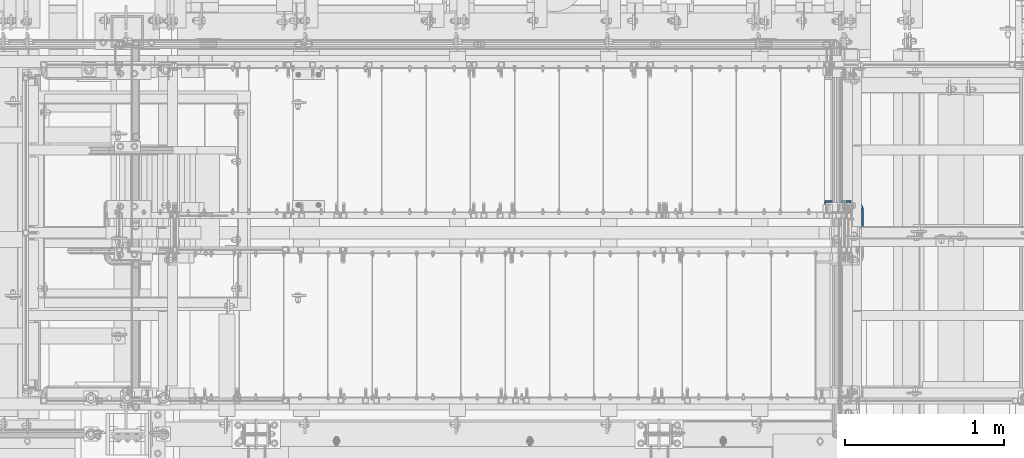
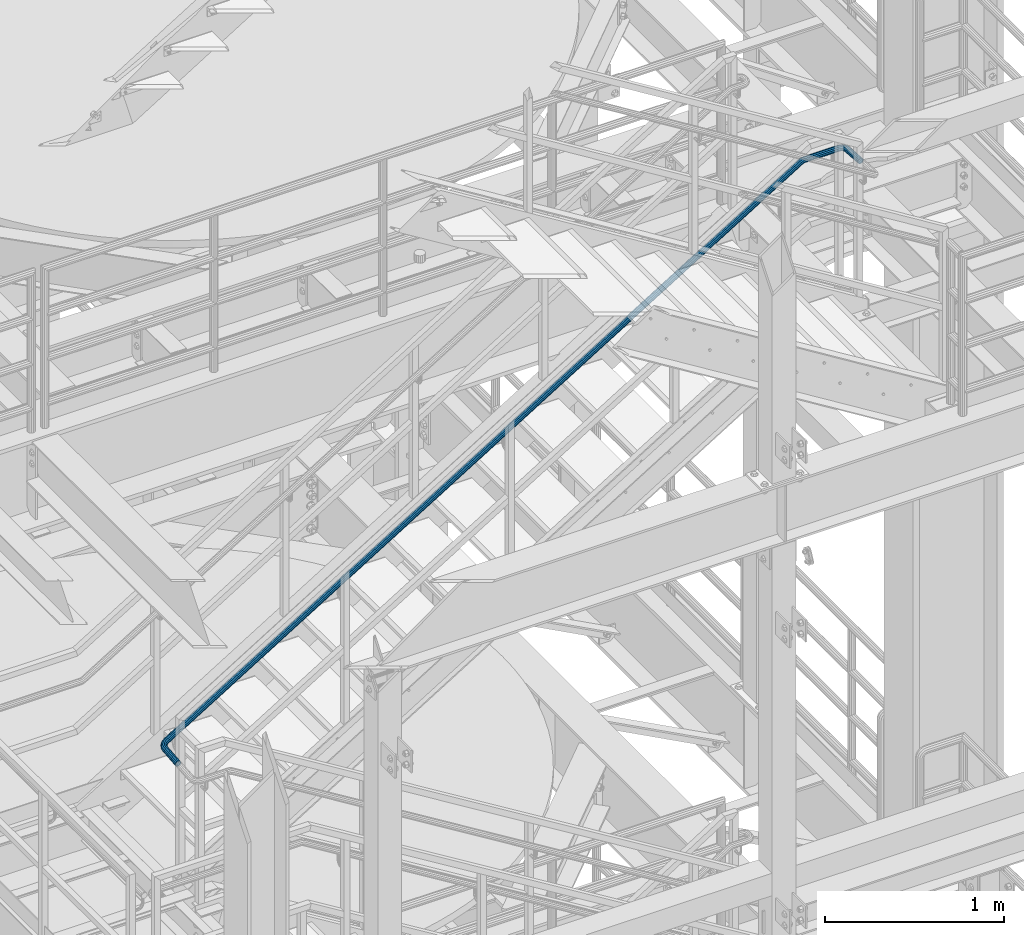
# One storey, part 973 of 1876: 1 beam, 1 element without a shape of its own.
"""IFC2X3 building model written with IfcOpenShell, lengths in millimetres."""

from ifc_helpers import new_model, si_unit, frame, origin_with_axes, place, context, subcontext, project, spatial, faceted_brep, material, type_object, element, aggregate, save


model = new_model("IFC2X3")

# Units and contexts
model_context = context("Model", 3, precision=1e-05, world=origin_with_axes())
body_context = subcontext(model_context, "Body", "Model", "MODEL_VIEW")
ifc_project = project(units=[si_unit("LENGTHUNIT", "METRE", prefix="MILLI"), si_unit("AREAUNIT", "SQUARE_METRE"), si_unit("VOLUMEUNIT", "CUBIC_METRE"), si_unit("MASSUNIT", "GRAM", prefix="KILO"), si_unit("TIMEUNIT", "SECOND"), si_unit("PLANEANGLEUNIT", "RADIAN"), si_unit("SOLIDANGLEUNIT", "STERADIAN"), si_unit("THERMODYNAMICTEMPERATUREUNIT", "DEGREE_CELSIUS"), si_unit("LUMINOUSINTENSITYUNIT", "LUMEN")], contexts=[model_context])

# Site, building, storey
site_placement = place(None, origin_with_axes())
site = spatial("IfcSite", under=ifc_project, at=site_placement, CompositionType="ELEMENT")
building_placement = place(site_placement, origin_with_axes())
building = spatial("IfcBuilding", under=site, at=building_placement, Name="Undefined", CompositionType="ELEMENT")
storey_placement = place(building_placement, origin_with_axes())
storey = spatial("IfcBuildingStorey", under=building, at=storey_placement, Name="Undefined", CompositionType="ELEMENT", Elevation=0.0)

# Assembly, beam
assembly_placement = place(storey_placement, origin_with_axes())
assembly = element("IfcElementAssembly", 1, at=assembly_placement, inside=storey, Name="RAIL", AssemblyPlace="NOTDEFINED", PredefinedType="RIGID_FRAME")
ifc_material = material()
beam_type = type_object("IfcBeamType", PredefinedType="NOTDEFINED")
beam_placement = place(assembly_placement, frame((1955.79988566379, -5842.00000419529, 11670.5472666668), z_axis=(0.0, -0.0872433640297696, 0.996187028339944), x_axis=(0.0, 0.996187028339944, 0.0872433640297696)))
beam = element("IfcBeam", 2, at=beam_placement, type_object=beam_type, material=ifc_material, context=body_context, shape_type="Brep", body=[
    faceted_brep([(0.0, -19.0500000000002, 0.0), (0.0, -16.4977839420935, -9.52500000000146), (148.458402180741, -16.4977839420292, -9.52500050397794), (148.458402213087, -19.0499999999354, -5.03972842125222e-07), (0.0, -9.52500000000009, -16.4977839420935), (148.458402157061, -9.52499999993552, -16.4977844460755), (0.0, 0.0, -19.05), (148.45840214839, 6.45741238258779e-11, -19.0500005039867), (0.0, 9.52500000000009, -16.4977839420935), (148.458402157053, 9.52500000006444, -16.4977844460773), (0.0, 16.4977839420935, -9.52500000000146), (148.458402180727, 16.4977839421581, -9.52500050397794), (-9.09494701772928e-13, 19.05, -1.81898940354586e-12), (148.45840221307, 19.0500000000645, -5.03972842125222e-07), (0.0, 16.4977839420935, 9.52500000000146), (148.458402245416, 16.4977839421581, 9.52499949603225), (0.0, 9.52500000000009, 16.4977839420935), (148.458402269095, 9.52500000006444, 16.4977834381298), (0.0, 0.0, 19.0499999999993), (148.458402277767, 6.43467501504347e-11, 19.0499994960373), (0.0, -9.52500000000009, 16.4977839420935), (148.458402269104, -9.52499999993552, 16.4977834381298), (0.0, -16.4977839420935, 9.52500000000146), (148.45840224543, -16.4977839420292, 9.52499949603225), (0.0, -15.875, 0.0), (0.0, -13.7481532850779, 7.9375), (148.458402240038, -13.7481532850136, 7.9374994960308), (148.458402213086, -15.8749999999354, -5.03972842125222e-07), (0.0, -7.9375, 13.7481532850798), (148.458402259766, -7.93749999993543, 13.7481527811105), (0.0, 0.0, 15.875), (148.458402266986, 6.45741238258779e-11, 15.8749994960344), (0.0, 7.9375, 13.7481532850798), (148.45840225976, 7.93750000006457, 13.7481527811124), (0.0, 13.7481532850779, 7.9375), (148.458402240027, 13.7481532851425, 7.93749949603261), (0.0, 15.875, 0.0), (148.458402213072, 15.8750000000643, -5.03972842125222e-07), (0.0, 13.7481532850779, -7.9375), (148.458402186119, 13.7481532851425, -7.9375005039783), (0.0, 7.9375, -13.7481532850798), (148.458402166391, 7.93750000006435, -13.7481537890599), (0.0, 0.0, -15.875), (148.458402159173, 6.43467501504347e-11, -15.8750005039819), (0.0, -7.9375, -13.7481532850798), (148.458402166398, -7.93749999993565, -13.7481537890599), (0.0, -13.7481532850779, -7.9375), (148.458402186132, -13.7481532850136, -7.9375005039783), (155.022269790611, -19.9102000558848, 0.52713515173491), (154.181198255556, -17.2477609014902, 9.98458978965937), (154.872494536664, -10.3655718826333, 17.0128908337792), (156.910926353682, -1.1077099890756, 19.7288106951564), (159.750297547414, 8.0451881611657, 17.4046208402306), (162.629800899487, 14.6406109003287, 10.6630860636851), (164.77787581211, 16.9113200317133, 1.3105951646412), (165.618947347166, 14.2488808773185, -8.14685947328144), (164.927651066063, 7.3666918584604, -15.1751605173995), (162.88921924904, -1.89117003509614, -17.8910803787785), (160.049848055309, -11.0440681853374, -15.5668905238508), (157.170344703236, -17.6394909245005, -8.82535574730719), (164.665801589533, 11.6241607290845, -6.63590536803531), (163.964908643658, 13.8428600244122, 1.24530683023477), (162.174846216466, 11.9506024149264, 9.03904924610288), (159.775260089738, 6.45441679895703, 14.6569948932229), (157.409117428295, -1.17299832624394, 16.5938197723299), (155.710424247446, -8.88788323754216, 14.330553221178), (155.13434401319, -14.6230407532562, 8.47363568441506), (155.83523695907, -16.8417400485851, 0.59242348614498), (157.625299386256, -14.9494824390981, -7.20131892972313), (160.024885512984, -9.45329682312877, -12.8192645768468), (162.391028174427, -1.8258816979278, -14.7560894559501), (164.089721355275, 5.88900321337042, -12.4928229048019), (175.492975740484, 9.24053554491456, 13.9722841117782), (179.590827401556, 10.6927110329329, 5.12139546023172), (169.999788567799, 3.74236055065012, 20.0414189944859), (164.583160950299, -4.32858240030237, 21.7025803177803), (160.69447388379, -12.8096906620774, 18.5106612465806), (159.375697927362, -19.4284581250115, 11.3209339183268), (160.980198033538, -22.4113913925221, 2.05987996441763), (165.07804969461, -20.9592159045037, -6.79100868712885), (170.571236867293, -15.461040910239, -12.8601435698365), (175.987864484794, -7.39009795928678, -14.5213048931291), (179.876551551302, 1.09101030248848, -11.3293858219295), (181.195327507731, 7.70977776542259, -4.13965849367378), (178.278045079009, -0.067381444558805, -8.84271523288771), (179.377025042701, 5.44825810788643, -2.85127579267646), (175.037472523586, -7.13497166270463, -11.5026477922202), (170.523616175668, -13.860757455165, -10.1183466894763), (165.945960198433, -18.4425699503854, -5.06073428722084), (162.531083814206, -19.6527161904007, 2.31500625573608), (161.194000392393, -17.1669384674753, 10.032551217324), (162.292980356083, -11.6512989150301, 16.0239906575371), (165.533552911506, -4.58370869688429, 18.6839232168695), (170.047409259425, 2.14207709557604, 17.2996221141257), (174.625065236661, 6.72388959079649, 12.2420097118702), (178.039941620888, 7.93403583081181, 4.8662691689151), (185.860470812277, 0.796062461570045, 19.1471070881344), (191.529808601814, 0.968240011728767, 11.0806087322471), (178.26069996454, -2.98626998648501, 24.1647635252029), (170.766848519916, -9.36528440747384, 24.7891010532385), (165.38688792119, -16.631729038786, 20.8528289358037), (163.562374266103, -22.8385659096161, 13.4106681079484), (165.782184515115, -26.3226780928735, 4.456739553445), (171.451522304651, -26.1505005427146, -3.60975880244223), (179.051293152387, -22.3681680946597, -8.62741523951081), (186.545144597012, -15.9891536736709, -9.25175276754453), (191.925105195738, -8.72270904235847, -5.31548065010975), (193.749618850825, -2.51587217152837, 2.12668017774558), (189.713587089525, -9.38179404206085, -3.1347881846159), (191.234015135431, -4.20942998303576, 3.06701250526021), (185.230286590588, -15.4371645681545, -6.41501494914701), (178.985410386734, -20.7530099189785, -5.89473367578285), (172.65226801362, -23.904953625691, -1.71335331156115), (167.927819855673, -24.0484349174899, 5.00872865167912), (166.077977981497, -21.1450080981087, 12.4703357804319), (167.598406027402, -15.9726440390837, 18.672136470308), (172.081706526341, -9.91727351299028, 21.9523632348391), (178.326582730195, -4.60142816216626, 21.4320819614768), (184.659725103308, -1.44948445545378, 17.2507015972533), (189.384173261256, -1.30600316365485, 10.5286196340148), (192.775217278823, -9.91326208815167, 25.709844439878), (199.492679815829, -11.3643845597019, 18.6381139272908), (183.770430858598, -11.5195541222913, 29.3940104558624), (174.891145804469, -15.7528560087642, 28.7034426664832), (168.516559376058, -21.4788579257731, 23.8231781532195), (166.354736858938, -27.1632822837962, 16.060879851253), (168.98493685075, -31.2829921666655, 7.49644932200499), (175.702399387758, -32.7341146382157, 0.424718809417755), (184.707185807983, -31.1278226040761, -3.25944720656844), (193.586470862109, -26.894520717603, -2.56887941718742), (199.961057290522, -21.1685188005933, 2.31138509607626), (202.122879807643, -15.4840944425712, 10.0736833980427), (197.340682464316, -21.1943803943591, 4.10403451750426), (199.142201228583, -16.4573600960066, 10.5726164358093), (192.028527107306, -25.9660486585331, 0.0371474231178581), (184.629122895533, -29.4938002305939, -0.538325734698446), (177.125134212013, -30.8323769257104, 2.53181261195459), (171.527248764507, -29.6231081994185, 8.42492137244335), (169.335415437996, -26.1900166303608, 15.5619468134864), (171.136934202264, -21.4529963320081, 22.0305287317897), (176.449089559273, -16.6813280678341, 26.0974158261779), (183.848493771047, -13.1535764957732, 26.6728889839942), (191.352482454568, -11.814999800657, 23.6027506373393), (196.950367902072, -13.0242685269479, 17.7096418768506), (187.016794634038, -40.9313624003119, 2.74821991076351), (177.438263879441, -40.1022959653355, 4.939983866072), (196.46182764119, -39.0994769396575, 4.91038987612046), (203.242573934144, -35.0974918131806, 10.8471420660244), (205.542138019625, -29.9977357036425, 18.9677285255348), (202.744353557984, -25.1666841421893, 27.096244670749), (195.598884636313, -21.8988134933056, 33.0546611649006), (186.020353881716, -21.0697470583293, 35.2464251202109), (176.575320874565, -22.9016325189839, 33.084255154854), (169.794574581611, -26.9036176454604, 27.1475029649464), (167.49501049613, -32.0033737549986, 19.0269165054397), (170.292794957772, -36.8344253164516, 10.8984003602236), (200.455240654767, -34.4146689658708, 12.2055054742686), (202.371544059334, -30.1648722079221, 18.9726608571927), (194.80461874397, -37.7496565712679, 7.25821198268022), (186.933757904678, -39.2762277884801, 5.45640367821761), (178.951648942514, -38.5853390926663, 7.28287364097559), (172.99709150779, -35.86211355193, 12.2482207194353), (170.665604456421, -31.836237250719, 19.0219841737817), (172.581907860987, -27.5864404927706, 25.7891395567021), (178.232529771783, -24.2514528873733, 30.7364330482924), (186.103390611077, -22.7248816701613, 32.5382413527568), (194.08549957324, -23.415770365975, 30.7117713899988), (200.040057007966, -26.1389959067112, 25.746424311541), (396.6465337138, -4124.635853978, 2507.9662866978), (389.501064792132, -4121.36798332912, 2513.92470319194), (406.225064468397, -4125.46492041297, 2505.77452274249), (415.670097475549, -4123.63303495232, 2507.93669270785), (422.450843768504, -4119.63104982585, 2513.87344489775), (424.750407853984, -4114.53129371632, 2521.99403135726), (421.952623392343, -4109.70024215487, 2530.12254750248), (414.807154470673, -4106.43237150599, 2536.08096399662), (405.228623716076, -4105.60330507101, 2538.27272795193), (395.783590708926, -4107.43519053166, 2536.11055798658), (389.00284441597, -4111.43717565814, 2530.17380579667), (386.703280330489, -4116.53693176767, 2522.05321933717), (389.873874290781, -4116.36979526339, 2522.04828700551), (392.205361342149, -4120.3956715646, 2515.27452355116), (391.790177695348, -4112.11999850545, 2528.81544238843), (397.440799606144, -4108.78501090005, 2533.76273588002), (405.311660445435, -4107.25843968284, 2535.56454418448), (413.2937694076, -4107.94932837865, 2533.73807422172), (419.248326842326, -4110.67255391939, 2528.77272714327), (421.579813893693, -4114.6984302206, 2521.99896368892), (419.663510489126, -4118.94822697854, 2515.231808306), (414.012888578329, -4122.28321458393, 2510.28451481441), (406.142027739036, -4123.80978580114, 2508.48270650995), (398.159918776873, -4123.11889710533, 2510.3091764727), (389.760968509095, -4128.15501266304, 2516.89240984029), (387.052053058895, -4125.6446535279, 2526.03567544415), (389.445429077094, -4122.99466745888, 2535.2274520339), (396.299793392433, -4120.91511608314, 2542.00481049532), (405.778524621986, -4119.9632135124, 2544.55176310186), (415.341804387525, -4120.39402127179, 2542.18585595943), (422.427159598881, -4122.09210477008, 2535.54103197621), (425.136075049081, -4124.60246390522, 2526.39776637236), (422.742699030881, -4127.25244997424, 2517.2059897826), (415.888334715542, -4129.33200134998, 2510.42863132118), (406.409603485989, -4130.28390392071, 2507.88167871464), (396.84632372045, -4129.85309616133, 2510.24758585708), (421.962406549898, -4124.68931304045, 2526.36759212834), (419.704977008065, -4122.5973470945, 2533.98698013155), (413.800514331936, -4121.18227751259, 2539.5243334509), (405.83111452732, -4120.82327104643, 2541.49592273626), (397.932171836026, -4121.61652318871, 2539.37346223081), (392.220201573243, -4123.3494826685, 2533.72566351296), (390.225721558077, -4125.55780439268, 2526.06584968816), (392.48315109991, -4127.64977033863, 2518.44646168495), (398.387613776039, -4129.06483992053, 2512.9091083656), (406.357013580655, -4129.42384638669, 2510.93751908025), (414.255956271951, -4128.63059424441, 2513.05997958569), (419.967926534732, -4126.89763476462, 2518.70777830355), (406.472705691783, -4135.49673571759, 2508.602210294), (396.914640926641, -4135.49673571759, 2511.02766483933), (415.962959862084, -4135.49673571759, 2511.28073742459), (422.842497496645, -4135.49673571759, 2518.34553704957), (425.267952041986, -4135.49673571759, 2527.90360181473), (422.589424911405, -4135.49673571759, 2537.39385598504), (415.524625286446, -4135.49673571758, 2544.2733936196), (405.966560521304, -4135.49673571758, 2546.69884816493), (396.476306351004, -4135.49673571758, 2544.02032103434), (389.596768716442, -4135.49673571758, 2536.95552140936), (387.171314171101, -4135.49673571758, 2527.3974566442), (389.849841301677, -4135.4967357176, 2517.90720247389), (420.072020098294, -4135.49673571759, 2519.89636907955), (422.093232219412, -4135.49673571759, 2527.86142305052), (414.339072069493, -4135.49673571759, 2514.00903605874), (406.430526927576, -4135.49673571759, 2511.77693011658), (398.465472956625, -4135.49673571759, 2513.79814223769), (392.57813993582, -4135.4967357176, 2519.53109026648), (390.346033993676, -4135.49673571759, 2527.43963540841), (392.367246114793, -4135.49673571758, 2535.40468937938), (398.100194143593, -4135.49673571758, 2541.29202240019), (406.008739285509, -4135.49673571758, 2543.52412834235), (413.973793256462, -4135.49673571758, 2541.50291622124), (419.861126277261, -4135.49673571759, 2535.76996819244), (396.914640926636, -4356.10019683838, 2511.02766483932), (389.849841301684, -4356.10019683839, 2517.90720247389), (406.47270569178, -4356.10019683838, 2508.60221029399), (415.96295986208, -4356.10019683838, 2511.28073742458), (422.842497496643, -4356.10019683838, 2518.34553704955), (425.267952041985, -4356.10019683838, 2527.90360181471), (422.589424911404, -4356.10019683838, 2537.39385598501), (415.524625286444, -4356.10019683838, 2544.27339361957), (405.966560521301, -4356.10019683838, 2546.69884816491), (396.476306351001, -4356.10019683838, 2544.02032103432), (389.596768716438, -4356.10019683838, 2536.95552140935), (387.171314171097, -4356.10019683838, 2527.3974566442), (390.346033993671, -4356.10019683838, 2527.4396354084), (392.578139935826, -4356.10019683838, 2519.53109026649), (392.367246114789, -4356.10019683838, 2535.40468937936), (398.100194143591, -4356.10019683838, 2541.29202240017), (406.008739285508, -4356.10019683838, 2543.52412834233), (413.97379325646, -4356.10019683838, 2541.50291622122), (419.86112627726, -4356.10019683838, 2535.76996819242), (422.093232219411, -4356.10019683838, 2527.8614230505), (420.072020098292, -4356.10019683838, 2519.89636907954), (414.339072069491, -4356.10019683838, 2514.00903605873), (406.430526927573, -4356.10019683838, 2511.77693011656), (398.46547295662, -4356.10019683838, 2513.79814223768), (388.716469614928, -4363.34380102947, 2518.08526622613), (386.237098372816, -4362.07095607909, 2527.54423106286), (388.618428593506, -4362.35296342646, 2537.10922819), (395.222384767452, -4364.11425943059, 2544.21732435175), (404.279442170998, -4366.88290624954, 2546.96391092184), (413.362769587057, -4369.91704720405, 2544.61304224687), (420.038496769912, -4372.40368667563, 2537.79463168981), (422.517868012024, -4373.67653162601, 2528.33566685309), (420.136537791334, -4373.39452427864, 2518.77066972594), (413.532581617388, -4371.63322827451, 2511.66257356419), (404.475524213844, -4368.86458145556, 2508.9159869941), (395.392196797784, -4365.83044050105, 2511.26685566907), (419.494470542091, -4372.70940033043, 2528.26971387057), (417.428327840331, -4371.64869620512, 2536.15218456784), (411.865221854619, -4369.57649664547, 2541.83419336538), (404.295782341233, -4367.04804585004, 2543.79325059453), (396.748234504948, -4364.74084016758, 2541.50442845279), (391.244937693325, -4363.27309349748, 2535.58101498466), (389.26049584275, -4363.03808737467, 2527.61018404537), (391.32663854451, -4364.09879149998, 2519.72771334811), (396.889744530223, -4366.17099105963, 2514.04570455056), (404.459184043606, -4368.69944185505, 2512.08664732141), (412.006731879894, -4371.00664753751, 2514.37546946315), (417.510028691516, -4372.47439420762, 2520.29888293128), (407.088819987282, -4382.38140798828, 2545.59874095466), (412.635414965283, -4387.11127733453, 2538.95772808586), (399.38323401905, -4376.61012893599, 2547.7331530032), (391.583362597981, -4371.34384973902, 2544.78905024675), (385.779174972421, -4367.99366565531, 2537.55530264134), (383.525898529353, -4367.45725580459, 2527.97018701608), (385.427296872023, -4369.87835077317, 2518.60202736214), (390.973891850022, -4374.60822011942, 2511.96101449334), (398.679477818256, -4380.37949917171, 2509.8266024448), (406.479349239324, -4385.64577836869, 2512.77070520125), (412.283536864885, -4388.99596245239, 2520.00445280666), (414.536813307952, -4389.53237230311, 2529.58956843191), (410.074840040513, -4387.24577105264, 2521.46702362622), (411.952570409736, -4387.69277926157, 2529.45461998059), (405.238017019211, -4384.45395098288, 2515.43890062171), (398.738124168322, -4380.0653849854, 2512.985481658), (392.316802528127, -4375.25598577516, 2514.76415836511), (387.694640046461, -4371.31442798662, 2520.29833575578), (386.110141427569, -4369.29684884613, 2528.1051354674), (387.987871796792, -4369.74385705507, 2536.09273182178), (392.824694818095, -4372.53567712482, 2542.12085482629), (399.324587668984, -4376.9242431223, 2544.57427379), (405.745909309177, -4381.73364233254, 2542.79559708289), (410.368071790845, -4385.67520012109, 2537.26141969222), (397.316914387123, -4392.27318071319, 2547.13400268566), (401.104844724857, -4398.78328736756, 2540.76929319415), (391.757211033261, -4384.32969656762, 2548.93127563443), (385.915452687099, -4377.08128509276, 2545.67953420525), (381.356933779863, -4372.47015228969, 2538.25007988807), (379.303105771432, -4371.73184746919, 2528.63362896737), (380.304290218058, -4375.06419881169, 2519.40690170142), (384.092220555791, -4381.57430546607, 2513.04219220991), (389.651923909651, -4389.51778961163, 2511.24491926114), (395.493682255816, -4396.7662010865, 2514.49666069032), (400.052201163052, -4401.37733388957, 2521.9261150075), (402.106029171482, -4402.11563871006, 2531.5425659282), (398.494262214452, -4398.96840208958, 2523.28644541422), (400.205785554811, -4399.58365610666, 2531.3001545148), (394.695496458422, -4395.12579142036, 2517.09523348323), (389.827364503286, -4389.08544852463, 2514.38544895892), (385.194278375067, -4382.46587840333, 2515.88317641622), (382.037669760291, -4377.04078952468, 2521.18710099249), (381.203349388104, -4374.2638300726, 2528.87604038078), (382.914872728461, -4374.87908408968, 2536.88974948136), (386.713638484491, -4378.7216947589, 2543.08096141234), (391.581770439627, -4384.76203765462, 2545.79074593666), (396.214856567845, -4391.38160777593, 2544.29301847935), (399.371465182624, -4396.80669665457, 2538.98909390309), (385.003594991588, -4398.62408974443, 2549.06854532484), (386.575478601972, -4406.27717910902, 2543.05199839996), (382.147861477106, -4389.28596407927, 2550.44099822458), (378.773469547526, -4380.76494534432, 2546.80160945304), (375.784584795326, -4375.3442336283, 2539.12555029249), (373.982076476128, -4374.47630425794, 2529.46961459607), (373.84892523841, -4378.39371820709, 2520.42110253578), (375.420808848791, -4386.04680757168, 2514.4045556109), (378.276542363273, -4395.38493323684, 2513.03210271116), (381.650934292854, -4403.90595197179, 2516.6714914827), (384.639819045053, -4409.32666368781, 2524.34755064324), (386.442327364252, -4410.19459305817, 2534.00348633967), (383.901882857577, -4406.49479451618, 2525.57905061402), (385.403973123575, -4407.21806899149, 2533.62566369437), (381.411145564076, -4401.97753475284, 2519.18233464689), (378.599152289426, -4394.87668580705, 2516.14951067061), (376.21937436069, -4387.09491441941, 2517.29322142039), (374.909471352039, -4380.71733994892, 2522.30701052446), (375.020430716804, -4377.45282832462, 2529.84743724137), (376.522520982803, -4378.17610279993, 2537.89405032172), (379.013258276304, -4382.69336256327, 2544.29076628884), (381.825251550954, -4389.79421150906, 2547.32359026513), (384.205029479689, -4397.5759828967, 2546.17987951535), (385.51493248834, -4403.95355736719, 2541.16609041128), (365.666834781839, -4397.40661315052, 2515.01321082671), (365.808474924193, -4387.5879267684, 2515.91474707445), (366.306129969166, -4406.36614246235, 2519.08230998748), (367.555061857005, -4412.06581606022, 2527.03173272272), (369.078980154608, -4412.97841100647, 2536.73143763022), (370.469552184799, -4408.85939822223, 2545.5823966132), (371.354175295072, -4400.81246385665, 2551.21300235993), (371.495815437426, -4390.99377747453, 2552.11453860767), (370.856520250099, -4382.03424816271, 2548.0454394469), (369.607588362261, -4376.33457456483, 2540.09601671166), (368.08367006466, -4375.42197961859, 2530.39631180416), (366.69309803447, -4379.5409924028, 2521.54535282116), (367.726105732444, -4409.08821260227, 2528.12042305513), (368.99603764711, -4409.84870839081, 2536.20351047805), (366.685329159245, -4404.33848460404, 2521.4959041091), (366.152583169804, -4396.87221017752, 2518.10498814179), (366.270616621765, -4388.68997152576, 2518.85626834824), (367.007802546997, -4381.98419288775, 2523.54843980383), (368.166612572155, -4378.55168223424, 2530.92423895634), (369.436544486824, -4379.31217802278, 2539.00732637925), (370.477321060021, -4384.06190602101, 2545.63184532528), (371.01006704946, -4391.52818044753, 2549.02276129259), (370.8920335975, -4399.71041909929, 2548.27148108614), (370.154847672271, -4406.41619773728, 2543.57930963053), (221.100885090511, -4387.58792676838, 2538.64972159702), (221.985508200786, -4379.5409924028, 2544.28032734375), (220.959244948157, -4397.40661315049, 2537.74818534928), (221.598540135486, -4406.36614246232, 2541.81728451006), (222.847472023326, -4412.06581606019, 2549.7667072453), (224.371390320931, -4412.97841100644, 2559.4664121528), (225.761962351124, -4408.8593982222, 2568.31737113578), (226.646585461401, -4400.81246385662, 2573.94797688251), (226.788225603754, -4390.9937774745, 2574.84951313025), (226.148930416426, -4382.03424816268, 2570.78041396947), (224.899998528585, -4376.3345745648, 2562.83099123423), (223.376080230981, -4375.42197961856, 2553.13128632673), (223.459022738476, -4378.55168223421, 2553.6592134789), (222.300212713315, -4381.98419288775, 2546.28341432642), (224.728954653147, -4379.31217802275, 2561.74230090182), (225.769731226347, -4384.06190602098, 2568.36681984786), (226.302477215787, -4391.5281804475, 2571.75773581517), (226.184443763826, -4399.71041909927, 2571.00645560872), (225.447257838597, -4406.41619773725, 2566.31428415312), (224.288447813435, -4409.84870839078, 2558.93848500063), (223.018515898765, -4409.08821260224, 2550.85539757771), (221.977739325564, -4404.33848460402, 2544.23087863168), (221.444993336123, -4396.87221017749, 2540.83996266436), (221.563026788084, -4388.68997152573, 2541.59124287081)], [[[0, 1, 2, 3]], [[1, 4, 5, 2]], [[4, 6, 7, 5]], [[6, 8, 9, 7]], [[8, 10, 11, 9]], [[10, 12, 13, 11]], [[12, 14, 15, 13]], [[14, 16, 17, 15]], [[16, 18, 19, 17]], [[18, 20, 21, 19]], [[20, 22, 23, 21]], [[22, 0, 3, 23]], [[24, 25, 26, 27]], [[25, 28, 29, 26]], [[28, 30, 31, 29]], [[30, 32, 33, 31]], [[32, 34, 35, 33]], [[34, 36, 37, 35]], [[36, 38, 39, 37]], [[38, 40, 41, 39]], [[40, 42, 43, 41]], [[42, 44, 45, 43]], [[44, 46, 47, 45]], [[46, 24, 27, 47]], [[22, 20, 18, 16, 14, 12, 10, 8, 6, 4, 1, 0], [46, 44, 42, 40, 38, 36, 34, 32, 30, 28, 25, 24]], [[23, 3, 48, 49]], [[21, 23, 49, 50]], [[19, 21, 50, 51]], [[17, 19, 51, 52]], [[15, 17, 52, 53]], [[13, 15, 53, 54]], [[11, 13, 54, 55]], [[9, 11, 55, 56]], [[7, 9, 56, 57]], [[5, 7, 57, 58]], [[2, 5, 58, 59]], [[3, 2, 59, 48]], [[37, 39, 60, 61]], [[35, 37, 61, 62]], [[33, 35, 62, 63]], [[31, 33, 63, 64]], [[29, 31, 64, 65]], [[26, 29, 65, 66]], [[27, 26, 66, 67]], [[47, 27, 67, 68]], [[45, 47, 68, 69]], [[43, 45, 69, 70]], [[41, 43, 70, 71]], [[39, 41, 71, 60]], [[53, 72, 73, 54]], [[52, 74, 72, 53]], [[51, 75, 74, 52]], [[50, 76, 75, 51]], [[49, 77, 76, 50]], [[48, 78, 77, 49]], [[59, 79, 78, 48]], [[58, 80, 79, 59]], [[57, 81, 80, 58]], [[56, 82, 81, 57]], [[55, 83, 82, 56]], [[54, 73, 83, 55]], [[71, 84, 85, 60]], [[70, 86, 84, 71]], [[69, 87, 86, 70]], [[68, 88, 87, 69]], [[67, 89, 88, 68]], [[66, 90, 89, 67]], [[65, 91, 90, 66]], [[64, 92, 91, 65]], [[63, 93, 92, 64]], [[62, 94, 93, 63]], [[61, 95, 94, 62]], [[60, 85, 95, 61]], [[72, 96, 97, 73]], [[74, 98, 96, 72]], [[75, 99, 98, 74]], [[76, 100, 99, 75]], [[77, 101, 100, 76]], [[78, 102, 101, 77]], [[79, 103, 102, 78]], [[80, 104, 103, 79]], [[81, 105, 104, 80]], [[82, 106, 105, 81]], [[83, 107, 106, 82]], [[73, 97, 107, 83]], [[84, 108, 109, 85]], [[86, 110, 108, 84]], [[87, 111, 110, 86]], [[88, 112, 111, 87]], [[89, 113, 112, 88]], [[90, 114, 113, 89]], [[91, 115, 114, 90]], [[92, 116, 115, 91]], [[93, 117, 116, 92]], [[94, 118, 117, 93]], [[95, 119, 118, 94]], [[85, 109, 119, 95]], [[96, 120, 121, 97]], [[98, 122, 120, 96]], [[99, 123, 122, 98]], [[100, 124, 123, 99]], [[101, 125, 124, 100]], [[102, 126, 125, 101]], [[103, 127, 126, 102]], [[104, 128, 127, 103]], [[105, 129, 128, 104]], [[106, 130, 129, 105]], [[107, 131, 130, 106]], [[97, 121, 131, 107]], [[108, 132, 133, 109]], [[110, 134, 132, 108]], [[111, 135, 134, 110]], [[112, 136, 135, 111]], [[113, 137, 136, 112]], [[114, 138, 137, 113]], [[115, 139, 138, 114]], [[116, 140, 139, 115]], [[117, 141, 140, 116]], [[118, 142, 141, 117]], [[119, 143, 142, 118]], [[109, 133, 143, 119]], [[128, 144, 145, 127]], [[129, 146, 144, 128]], [[130, 147, 146, 129]], [[131, 148, 147, 130]], [[121, 149, 148, 131]], [[120, 150, 149, 121]], [[122, 151, 150, 120]], [[123, 152, 151, 122]], [[124, 153, 152, 123]], [[125, 154, 153, 124]], [[126, 155, 154, 125]], [[127, 145, 155, 126]], [[132, 156, 157, 133]], [[134, 158, 156, 132]], [[135, 159, 158, 134]], [[136, 160, 159, 135]], [[137, 161, 160, 136]], [[138, 162, 161, 137]], [[139, 163, 162, 138]], [[140, 164, 163, 139]], [[141, 165, 164, 140]], [[142, 166, 165, 141]], [[143, 167, 166, 142]], [[133, 157, 167, 143]], [[155, 145, 168, 169]], [[145, 144, 170, 168]], [[144, 146, 171, 170]], [[146, 147, 172, 171]], [[147, 148, 173, 172]], [[148, 149, 174, 173]], [[149, 150, 175, 174]], [[150, 151, 176, 175]], [[151, 152, 177, 176]], [[152, 153, 178, 177]], [[153, 154, 179, 178]], [[154, 155, 169, 179]], [[161, 162, 180, 181]], [[162, 163, 182, 180]], [[163, 164, 183, 182]], [[164, 165, 184, 183]], [[165, 166, 185, 184]], [[166, 167, 186, 185]], [[167, 157, 187, 186]], [[157, 156, 188, 187]], [[156, 158, 189, 188]], [[158, 159, 190, 189]], [[159, 160, 191, 190]], [[160, 161, 181, 191]], [[179, 169, 192, 193]], [[178, 179, 193, 194]], [[177, 178, 194, 195]], [[176, 177, 195, 196]], [[175, 176, 196, 197]], [[174, 175, 197, 198]], [[173, 174, 198, 199]], [[172, 173, 199, 200]], [[171, 172, 200, 201]], [[170, 171, 201, 202]], [[168, 170, 202, 203]], [[169, 168, 203, 192]], [[186, 187, 204, 205]], [[185, 186, 205, 206]], [[184, 185, 206, 207]], [[183, 184, 207, 208]], [[182, 183, 208, 209]], [[180, 182, 209, 210]], [[181, 180, 210, 211]], [[191, 181, 211, 212]], [[190, 191, 212, 213]], [[189, 190, 213, 214]], [[188, 189, 214, 215]], [[187, 188, 215, 204]], [[202, 216, 217, 203]], [[201, 218, 216, 202]], [[200, 219, 218, 201]], [[199, 220, 219, 200]], [[198, 221, 220, 199]], [[197, 222, 221, 198]], [[196, 223, 222, 197]], [[195, 224, 223, 196]], [[194, 225, 224, 195]], [[193, 226, 225, 194]], [[192, 227, 226, 193]], [[203, 217, 227, 192]], [[215, 228, 229, 204]], [[214, 230, 228, 215]], [[213, 231, 230, 214]], [[212, 232, 231, 213]], [[211, 233, 232, 212]], [[210, 234, 233, 211]], [[209, 235, 234, 210]], [[208, 236, 235, 209]], [[207, 237, 236, 208]], [[206, 238, 237, 207]], [[205, 239, 238, 206]], [[204, 229, 239, 205]], [[227, 217, 240, 241]], [[217, 216, 242, 240]], [[216, 218, 243, 242]], [[218, 219, 244, 243]], [[219, 220, 245, 244]], [[220, 221, 246, 245]], [[221, 222, 247, 246]], [[222, 223, 248, 247]], [[223, 224, 249, 248]], [[224, 225, 250, 249]], [[225, 226, 251, 250]], [[226, 227, 241, 251]], [[233, 234, 252, 253]], [[234, 235, 254, 252]], [[235, 236, 255, 254]], [[236, 237, 256, 255]], [[237, 238, 257, 256]], [[238, 239, 258, 257]], [[239, 229, 259, 258]], [[229, 228, 260, 259]], [[228, 230, 261, 260]], [[230, 231, 262, 261]], [[231, 232, 263, 262]], [[232, 233, 253, 263]], [[251, 241, 264, 265]], [[250, 251, 265, 266]], [[249, 250, 266, 267]], [[248, 249, 267, 268]], [[247, 248, 268, 269]], [[246, 247, 269, 270]], [[245, 246, 270, 271]], [[244, 245, 271, 272]], [[243, 244, 272, 273]], [[242, 243, 273, 274]], [[240, 242, 274, 275]], [[241, 240, 275, 264]], [[258, 259, 276, 277]], [[257, 258, 277, 278]], [[256, 257, 278, 279]], [[255, 256, 279, 280]], [[254, 255, 280, 281]], [[252, 254, 281, 282]], [[253, 252, 282, 283]], [[263, 253, 283, 284]], [[262, 263, 284, 285]], [[261, 262, 285, 286]], [[260, 261, 286, 287]], [[259, 260, 287, 276]], [[269, 288, 289, 270]], [[268, 290, 288, 269]], [[267, 291, 290, 268]], [[266, 292, 291, 267]], [[265, 293, 292, 266]], [[264, 294, 293, 265]], [[275, 295, 294, 264]], [[274, 296, 295, 275]], [[273, 297, 296, 274]], [[272, 298, 297, 273]], [[271, 299, 298, 272]], [[270, 289, 299, 271]], [[287, 300, 301, 276]], [[286, 302, 300, 287]], [[285, 303, 302, 286]], [[284, 304, 303, 285]], [[283, 305, 304, 284]], [[282, 306, 305, 283]], [[281, 307, 306, 282]], [[280, 308, 307, 281]], [[279, 309, 308, 280]], [[278, 310, 309, 279]], [[277, 311, 310, 278]], [[276, 301, 311, 277]], [[288, 312, 313, 289]], [[290, 314, 312, 288]], [[291, 315, 314, 290]], [[292, 316, 315, 291]], [[293, 317, 316, 292]], [[294, 318, 317, 293]], [[295, 319, 318, 294]], [[296, 320, 319, 295]], [[297, 321, 320, 296]], [[298, 322, 321, 297]], [[299, 323, 322, 298]], [[289, 313, 323, 299]], [[300, 324, 325, 301]], [[302, 326, 324, 300]], [[303, 327, 326, 302]], [[304, 328, 327, 303]], [[305, 329, 328, 304]], [[306, 330, 329, 305]], [[307, 331, 330, 306]], [[308, 332, 331, 307]], [[309, 333, 332, 308]], [[310, 334, 333, 309]], [[311, 335, 334, 310]], [[301, 325, 335, 311]], [[312, 336, 337, 313]], [[314, 338, 336, 312]], [[315, 339, 338, 314]], [[316, 340, 339, 315]], [[317, 341, 340, 316]], [[318, 342, 341, 317]], [[319, 343, 342, 318]], [[320, 344, 343, 319]], [[321, 345, 344, 320]], [[322, 346, 345, 321]], [[323, 347, 346, 322]], [[313, 337, 347, 323]], [[324, 348, 349, 325]], [[326, 350, 348, 324]], [[327, 351, 350, 326]], [[328, 352, 351, 327]], [[329, 353, 352, 328]], [[330, 354, 353, 329]], [[331, 355, 354, 330]], [[332, 356, 355, 331]], [[333, 357, 356, 332]], [[334, 358, 357, 333]], [[335, 359, 358, 334]], [[325, 349, 359, 335]], [[344, 360, 361, 343]], [[345, 362, 360, 344]], [[346, 363, 362, 345]], [[347, 364, 363, 346]], [[337, 365, 364, 347]], [[336, 366, 365, 337]], [[338, 367, 366, 336]], [[339, 368, 367, 338]], [[340, 369, 368, 339]], [[341, 370, 369, 340]], [[342, 371, 370, 341]], [[343, 361, 371, 342]], [[348, 372, 373, 349]], [[350, 374, 372, 348]], [[351, 375, 374, 350]], [[352, 376, 375, 351]], [[353, 377, 376, 352]], [[354, 378, 377, 353]], [[355, 379, 378, 354]], [[356, 380, 379, 355]], [[357, 381, 380, 356]], [[358, 382, 381, 357]], [[359, 383, 382, 358]], [[349, 373, 383, 359]], [[371, 361, 384, 385]], [[361, 360, 386, 384]], [[360, 362, 387, 386]], [[362, 363, 388, 387]], [[363, 364, 389, 388]], [[364, 365, 390, 389]], [[365, 366, 391, 390]], [[366, 367, 392, 391]], [[367, 368, 393, 392]], [[368, 369, 394, 393]], [[369, 370, 395, 394]], [[370, 371, 385, 395]], [[377, 378, 396, 397]], [[378, 379, 398, 396]], [[379, 380, 399, 398]], [[380, 381, 400, 399]], [[381, 382, 401, 400]], [[382, 383, 402, 401]], [[383, 373, 403, 402]], [[373, 372, 404, 403]], [[372, 374, 405, 404]], [[374, 375, 406, 405]], [[375, 376, 407, 406]], [[376, 377, 397, 407]], [[386, 387, 388, 389, 390, 391, 392, 393, 394, 395, 385, 384], [398, 399, 400, 401, 402, 403, 404, 405, 406, 407, 397, 396]]]),
])
aggregate(assembly, [beam])

save(model, "model.ifc")
